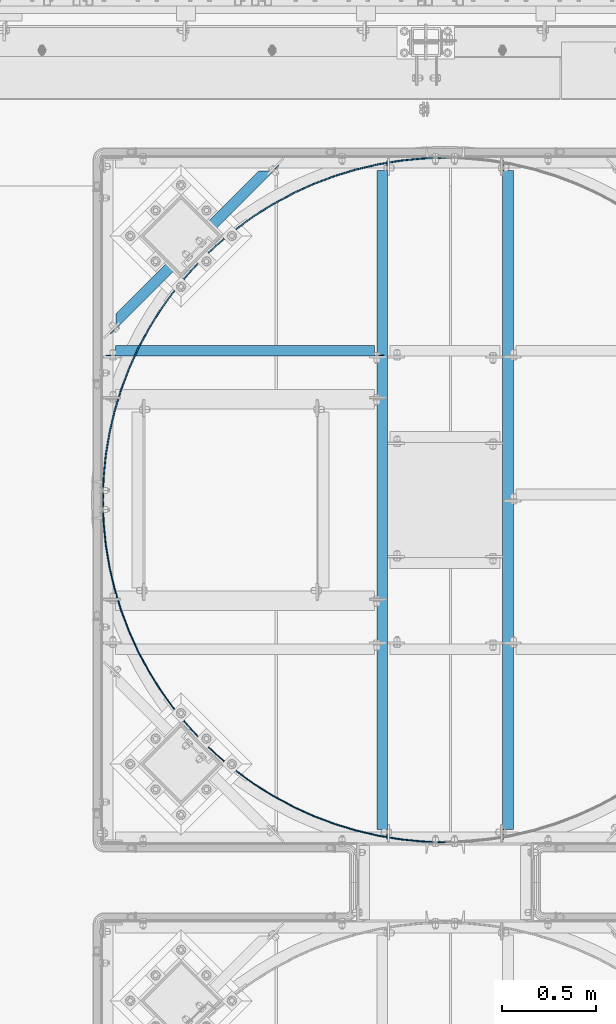
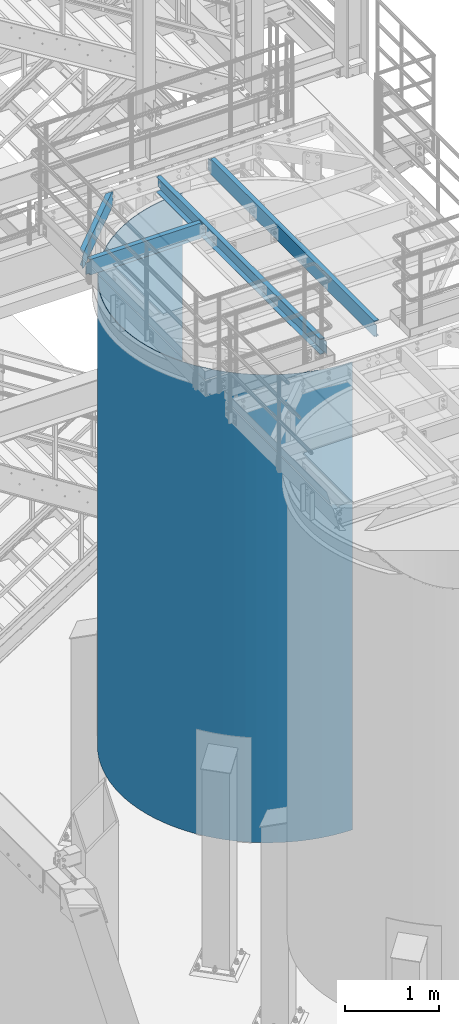
# One storey, part 939 of 1876: 5 beams, 5 elements without a shape of their own.
"""IFC2X3 building model written with IfcOpenShell, lengths in millimetres."""

from ifc_helpers import new_model, si_unit, frame, origin_with_axes, place, context, subcontext, project, spatial, faceted_brep, material, type_object, element, aggregate, save


model = new_model("IFC2X3")

# Units and contexts
model_context = context("Model", 3, precision=1e-05, world=origin_with_axes())
body_context = subcontext(model_context, "Body", "Model", "MODEL_VIEW")
ifc_project = project(units=[si_unit("LENGTHUNIT", "METRE", prefix="MILLI"), si_unit("AREAUNIT", "SQUARE_METRE"), si_unit("VOLUMEUNIT", "CUBIC_METRE"), si_unit("MASSUNIT", "GRAM", prefix="KILO"), si_unit("TIMEUNIT", "SECOND"), si_unit("PLANEANGLEUNIT", "RADIAN"), si_unit("SOLIDANGLEUNIT", "STERADIAN"), si_unit("THERMODYNAMICTEMPERATUREUNIT", "DEGREE_CELSIUS"), si_unit("LUMINOUSINTENSITYUNIT", "LUMEN")], contexts=[model_context])

# Site, building, storey
site_placement = place(None, origin_with_axes())
site = spatial("IfcSite", under=ifc_project, at=site_placement, CompositionType="ELEMENT")
building_placement = place(site_placement, origin_with_axes())
building = spatial("IfcBuilding", under=site, at=building_placement, Name="Undefined", CompositionType="ELEMENT")
storey_placement = place(building_placement, origin_with_axes())
storey = spatial("IfcBuildingStorey", under=building, at=storey_placement, Name="Undefined", CompositionType="ELEMENT", Elevation=0.0)

# Assembly, beam
assembly_1_placement = place(storey_placement, origin_with_axes())
assembly_1 = element("IfcElementAssembly", 1, at=assembly_1_placement, inside=storey, Name="BEAM", AssemblyPlace="NOTDEFINED", PredefinedType="RIGID_FRAME")
ifc_material = material(Name="STEEL/A36")
beam_type_1 = type_object("IfcBeamType", Name="C8X11.5", PredefinedType="NOTDEFINED")
beam_1_placement = place(assembly_1_placement, frame((3349.46494957744, -8680.05257802322, 7896.225), z_axis=(0.0, 0.0, -1.0), x_axis=(0.707106781186548, 0.707106781186547, 0.0)))
beam_1 = element("IfcBeam", 2, at=beam_1_placement, type_object=beam_type_1, material=ifc_material, Name="BEAM", ObjectType="C8X11.5", context=body_context, shape_type="Brep", body=[
    faceted_brep([(154.529650862243, -28.5750000000025, 101.6), (154.529650862243, -28.5750000000025, 96.8355949999996), (1223.65903142988, -28.5750000000044, 96.8355949999996), (1223.65903142988, -28.5750000000044, 101.6), (1280.80903142989, 28.5750000000044, 101.6), (1271.29165562398, 19.0576241940962, 88.899999809264), (1280.80903142989, 28.5750000000044, 88.899999809264), (97.3796508622331, 28.5750000000062, 101.6), (97.3796508622331, 28.5750000000062, 88.899999809265), (106.897026668147, 19.0576241940926, 88.899999809265), (1298.76954340093, 28.5750000000062, -76.2000000000007), (1292.41954340093, 22.225000000004, -76.2000000000007), (1285.5463530323, 22.225000000004, -77.1667299225883), (1291.8963530323, 28.5750000000062, -77.1667299225883), (1279.71954359166, 22.225000000004, -79.9197438230667), (1286.06954359167, 28.5750000000044, -79.9197438230667), (1275.8261939962, 22.225000000004, -84.0399202912204), (1282.17619399621, 28.5750000000062, -84.0399202912204), (1274.60747157567, 22.225000000004, -88.3723149999996), (1271.29165562261, 19.0576241940853, -88.8999998092659), (1280.80903142853, 28.5750000000062, -88.8999998092659), (103.581210715046, 22.225000000004, -88.3723149999996), (106.897026668097, 19.0576241940926, -88.899999809265), (154.529650862193, -28.5750000000044, -96.8355949999996), (1223.65903142852, -28.5750000000044, -96.8355949999996), (154.529650862193, -28.5750000000044, -101.6), (1223.65903142852, -28.5750000000044, -101.6), (1280.80903142853, 28.5750000000062, -101.6), (97.3796508621845, 28.5750000000044, -101.6), (97.3796508621845, 28.5750000000044, -88.899999809265), (102.362488294509, 22.225000000004, -84.0399202912195), (96.0124882945074, 28.5750000000062, -84.0399202912195), (98.4691386990489, 22.2250000000058, -79.9197438230658), (92.1191386990495, 28.5750000000044, -79.9197438230658), (92.6423292584141, 22.225000000004, -77.1667299225874), (86.2923292584137, 28.5750000000044, -77.1667299225874), (85.7691388897797, 22.225000000004, -76.1999999999998), (79.4191388897784, 28.5750000000062, -76.1999999999998), (59.1474759898592, 22.225000000004, -76.1999999999998), (59.1474759898588, 28.5750000000062, -76.1999999999998), (59.1474759898592, 22.225000000004, 76.1999999999998), (59.1474759898588, 28.5750000000062, 76.1999999999998), (85.7691388898302, 22.225000000004, 76.1999999999998), (79.4191388898289, 28.5750000000062, 76.1999999999998), (92.6423292584636, 22.225000000004, 77.1667299225874), (86.2923292584624, 28.5750000000062, 77.1667299225874), (98.4691386990994, 22.225000000004, 79.9197438230658), (92.119138699099, 28.5750000000062, 79.9197438230658), (102.362488294559, 22.225000000004, 84.0399202912195), (96.0124882945579, 28.5750000000062, 84.0399202912195), (103.581210715098, 22.225000000004, 88.3723149999996), (1274.60747157703, 22.225000000004, 88.3723149999996), (1275.82619399757, 22.225000000004, 84.0399202912186), (1282.17619399757, 28.5750000000062, 84.0399202912186), (1279.71954359303, 22.225000000004, 79.9197438230649), (1286.06954359303, 28.5750000000062, 79.9197438230649), (1285.54635303366, 22.225000000004, 77.1667299225865), (1291.89635303366, 28.5750000000044, 77.1667299225865), (1292.4195434023, 22.225000000004, 76.1999999999989), (1298.7695434023, 28.5750000000062, 76.1999999999989), (1319.04120629678, 22.225000000004, 76.1999999999989), (1319.04120629678, 28.5750000000062, 76.1999999999989), (1319.04120629678, 28.5750000000062, -76.2000000000007), (1319.04120629678, 22.225000000004, -76.2000000000007)], [[[0, 1, 2, 3]], [[4, 3, 2, 5, 6]], [[7, 0, 3, 4]], [[0, 7, 8, 9, 1]], [[10, 11, 12, 13]], [[13, 12, 14, 15]], [[15, 14, 16, 17]], [[17, 16, 18, 19, 20]], [[21, 22, 23, 24, 19, 18]], [[23, 25, 26, 24]], [[20, 19, 24, 26, 27]], [[25, 28, 27, 26]], [[23, 22, 29, 28, 25]], [[21, 30, 31, 29, 22]], [[32, 33, 31, 30]], [[34, 35, 33, 32]], [[36, 37, 35, 34]], [[37, 36, 38, 39]], [[39, 38, 40, 41]], [[42, 43, 41, 40]], [[44, 45, 43, 42]], [[46, 47, 45, 44]], [[48, 49, 47, 46]], [[9, 8, 49, 48, 50]], [[2, 1, 9, 50, 51, 5]], [[6, 5, 51, 52, 53]], [[53, 52, 54, 55]], [[55, 54, 56, 57]], [[57, 56, 58, 59]], [[59, 58, 60, 61]], [[10, 13, 15, 17, 20, 27, 28, 29, 31, 33, 35, 37, 39, 41, 43, 45, 47, 49, 8, 7, 4, 6, 53, 55, 57, 59, 61, 62]], [[11, 10, 62, 63]], [[58, 56, 54, 52, 51, 50, 48, 46, 44, 42, 40, 38, 36, 34, 32, 30, 21, 18, 16, 14, 12, 11, 63, 60]], [[62, 61, 60, 63]]]),
])
aggregate(assembly_1, [beam_1])

assembly_2_placement = place(storey_placement, origin_with_axes())
assembly_2 = element("IfcElementAssembly", 3, at=assembly_2_placement, inside=storey, Name="BEAM", AssemblyPlace="NOTDEFINED", PredefinedType="RIGID_FRAME")
beam_2_placement = place(assembly_2_placement, frame((3365.50333884985, -8747.08935546873, 7896.225), z_axis=(0.0, 0.0, -1.0), x_axis=(1.0, 0.0, 0.0)))
beam_2 = element("IfcBeam", 4, at=beam_2_placement, type_object=beam_type_1, material=ifc_material, Name="BEAM", ObjectType="C8X11.5", context=body_context, shape_type="Brep", body=[
    faceted_brep([(1441.45, -28.5750000000007, -96.8355949999996), (1441.45, -28.5750000000007, -101.6), (1441.45, 28.5750000000007, -101.6), (1441.45, 28.5750000000007, -88.899999809264), (1441.45, 19.0576241940926, -88.899999809264), (1441.55496303464, 22.2250000000004, -88.3723149999996), (1442.41672992259, 28.5750000000007, -84.0399202912186), (1442.41672992259, 22.2250000000004, -84.0399202912186), (1445.16974382306, 28.5750000000007, -79.9197438230649), (1445.16974382306, 22.2250000000004, -79.9197438230649), (1449.28992029122, 28.5750000000007, -77.1667299225865), (1449.28992029122, 22.2250000000004, -77.1667299225865), (1454.14999980926, 28.5750000000007, -76.1999999999989), (1454.14999980926, 22.2250000000004, -76.1999999999989), (1492.25, 22.2250000000004, -76.1999999999989), (1492.25, 28.5750000000007, -76.1999999999989), (69.8500000000013, 28.5750000000007, 101.6), (69.8500000000013, -28.5750000000007, 101.6), (1441.45, -28.5750000000007, 101.6), (1441.45, 28.5750000000007, 101.6), (69.8500000000013, 19.0576241940817, -88.8999998092659), (69.8500000000013, 28.5750000000007, -88.8999998092659), (69.8500000000013, 28.5750000000007, -101.6), (69.8500000000013, -28.5750000000007, -101.6), (69.8500000000013, -28.5750000000007, -96.8355949999996), (69.7450369653598, 22.2250000000004, -88.3723149999996), (68.8832700774137, 22.2250000000004, -84.0399202912204), (68.8832700774137, 28.5750000000007, -84.0399202912204), (66.1302561769353, 22.2250000000004, -79.9197438230667), (66.1302561769353, 28.5750000000007, -79.9197438230667), (62.0100797087816, 22.2250000000004, -77.1667299225883), (62.0100797087816, 28.5750000000007, -77.1667299225883), (57.1500001907361, 22.2250000000004, -76.2000000000007), (57.1500001907361, 28.5750000000007, -76.2000000000007), (19.0499999999993, 22.2250000000004, -76.2000000000007), (19.0499999999993, 28.5750000000007, -76.2000000000007), (19.0499999999993, 22.2250000000004, 76.1999999999989), (19.0499999999993, 28.5750000000007, 76.1999999999989), (57.1500001907361, 22.2250000000004, 76.1999999999989), (57.1500001907361, 28.5750000000007, 76.1999999999989), (62.0100797087816, 22.2250000000004, 77.1667299225865), (62.0100797087816, 28.5750000000007, 77.1667299225865), (66.1302561769353, 22.2250000000004, 79.9197438230649), (66.1302561769353, 28.5750000000007, 79.9197438230649), (68.8832700774137, 22.2250000000004, 84.0399202912186), (68.8832700774137, 28.5750000000007, 84.0399202912186), (69.8500000000013, 19.0576241940926, 88.899999809264), (69.8500000000013, 28.5750000000007, 88.899999809264), (69.7450369653607, 22.2250000000004, 88.3723149999996), (69.8500000000013, -28.5750000000007, 96.8355949999996), (1441.45, -28.5750000000007, 96.8355949999996), (1441.45, 19.0576241940817, 88.8999998092659), (1441.45, 28.5750000000007, 88.8999998092659), (1441.55496303464, 22.2250000000004, 88.3723149999996), (1442.41672992259, 22.2250000000004, 84.0399202912204), (1442.41672992259, 28.5750000000007, 84.0399202912204), (1445.16974382306, 22.2250000000004, 79.9197438230667), (1445.16974382306, 28.5750000000007, 79.9197438230667), (1449.28992029122, 22.2250000000004, 77.1667299225883), (1449.28992029122, 28.5750000000007, 77.1667299225883), (1454.14999980926, 22.2250000000004, 76.2000000000007), (1454.14999980926, 28.5750000000007, 76.2000000000007), (1492.25, 22.2250000000004, 76.2000000000007), (1492.25, 28.5750000000007, 76.2000000000007)], [[[0, 1, 2, 3, 4]], [[5, 4, 3, 6, 7]], [[7, 6, 8, 9]], [[9, 8, 10, 11]], [[11, 10, 12, 13]], [[14, 13, 12, 15]], [[16, 17, 18, 19]], [[20, 21, 22, 23, 24]], [[25, 26, 27, 21, 20]], [[28, 29, 27, 26]], [[30, 31, 29, 28]], [[32, 33, 31, 30]], [[34, 35, 33, 32]], [[36, 37, 35, 34]], [[38, 39, 37, 36]], [[40, 41, 39, 38]], [[42, 43, 41, 40]], [[44, 45, 43, 42]], [[46, 47, 45, 44, 48]], [[17, 16, 47, 46, 49]], [[17, 49, 50, 18]], [[18, 50, 51, 52, 19]], [[49, 46, 48, 53, 51, 50]], [[54, 55, 52, 51, 53]], [[56, 57, 55, 54]], [[58, 59, 57, 56]], [[60, 61, 59, 58]], [[62, 63, 61, 60]], [[63, 62, 14, 15]], [[10, 8, 6, 3, 2, 22, 21, 27, 29, 31, 33, 35, 37, 39, 41, 43, 45, 47, 16, 19, 52, 55, 57, 59, 61, 63, 15, 12]], [[23, 22, 2, 1]], [[24, 23, 1, 0]], [[25, 20, 24, 0, 4, 5]], [[62, 60, 58, 56, 54, 53, 48, 44, 42, 40, 38, 36, 34, 32, 30, 28, 26, 25, 5, 7, 9, 11, 13, 14]]]),
])
aggregate(assembly_2, [beam_2])

assembly_3_placement = place(storey_placement, origin_with_axes())
assembly_3 = element("IfcElementAssembly", 5, at=assembly_3_placement, inside=storey, Name="BEAM", AssemblyPlace="NOTDEFINED", PredefinedType="RIGID_FRAME")
beam_3_placement = place(assembly_3_placement, frame((5514.97833884985, -11353.7643554687, 7896.225), z_axis=(0.0, 0.0, 1.0), x_axis=(0.0, 1.0, 0.0)))
beam_3 = element("IfcBeam", 6, at=beam_3_placement, type_object=beam_type_1, material=ifc_material, Name="BEAM", ObjectType="C8X11.5", context=body_context, shape_type="Brep", body=[
    faceted_brep([(3562.3499511731, -28.5749999999998, -96.8355949999996), (3562.3499511731, -28.5749999999998, -101.6), (3562.3499511731, 28.5749999999998, -101.6), (3562.3499511731, 28.5749999999998, -88.899999809264), (3562.3499511731, 19.0576241940935, -88.899999809264), (3562.45491420774, 22.2250000000004, -88.3723149999996), (3563.31668109569, 28.5749999999998, -84.0399202912186), (3563.31668109569, 22.2250000000004, -84.0399202912186), (3566.06969499617, 28.5749999999998, -79.9197438230649), (3566.06969499617, 22.2250000000004, -79.9197438230649), (3570.18987146432, 28.5749999999998, -77.1667299225865), (3570.18987146432, 22.2250000000004, -77.1667299225865), (3575.04995098237, 28.5749999999998, -76.1999999999989), (3575.04995098237, 22.2250000000004, -76.1999999999989), (3613.1499511731, 22.2250000000004, -76.1999999999989), (3613.1499511731, 28.5749999999998, -76.1999999999989), (69.8500000000013, 28.5750000000007, 101.6), (69.8500000000013, -28.5750000000007, 101.6), (3562.3499511731, -28.5749999999998, 101.6), (3562.3499511731, 28.5749999999998, 101.6), (69.8500000000013, 19.0576241940817, -88.8999998092659), (69.8500000000013, 28.5750000000007, -88.8999998092659), (69.8500000000013, 28.5750000000007, -101.6), (69.8500000000013, -28.5750000000007, -101.6), (69.8500000000013, -28.5750000000007, -96.8355949999996), (69.7450369653598, 22.2250000000004, -88.3723149999996), (68.8832700774137, 22.2250000000004, -84.0399202912204), (68.8832700774137, 28.5750000000007, -84.0399202912204), (66.1302561769353, 22.2250000000004, -79.9197438230667), (66.1302561769353, 28.5750000000007, -79.9197438230667), (62.0100797087816, 22.2250000000004, -77.1667299225883), (62.0100797087816, 28.5750000000007, -77.1667299225883), (57.1500001907361, 22.2250000000004, -76.2000000000007), (57.1500001907361, 28.5750000000007, -76.2000000000007), (19.0499999999993, 22.2250000000004, -76.2000000000007), (19.0499999999993, 28.5750000000007, -76.2000000000007), (19.0499999999993, 22.2250000000004, 76.1999999999989), (19.0499999999993, 28.5750000000007, 76.1999999999989), (57.1500001907361, 22.2250000000004, 76.1999999999989), (57.1500001907361, 28.5750000000007, 76.1999999999989), (62.0100797087816, 22.2250000000004, 77.1667299225865), (62.0100797087816, 28.5750000000007, 77.1667299225865), (66.1302561769353, 22.2250000000004, 79.9197438230649), (66.1302561769353, 28.5750000000007, 79.9197438230649), (68.8832700774137, 22.2250000000004, 84.0399202912186), (68.8832700774137, 28.5750000000007, 84.0399202912186), (69.8500000000013, 19.0576241940926, 88.899999809264), (69.8500000000013, 28.5750000000007, 88.899999809264), (69.7450369653607, 22.2250000000004, 88.3723149999996), (69.8500000000013, -28.5750000000007, 96.8355949999996), (3562.3499511731, -28.5749999999998, 96.8355949999996), (3562.3499511731, 19.0576241940826, 88.8999998092659), (3562.3499511731, 28.5749999999998, 88.8999998092659), (3562.45491420775, 22.2250000000004, 88.3723149999996), (3563.31668109569, 22.2250000000004, 84.0399202912204), (3563.31668109569, 28.5749999999998, 84.0399202912204), (3566.06969499617, 22.2250000000004, 79.9197438230667), (3566.06969499617, 28.5749999999998, 79.9197438230667), (3570.18987146432, 22.2250000000004, 77.1667299225883), (3570.18987146432, 28.5749999999998, 77.1667299225883), (3575.04995098237, 22.2250000000004, 76.2000000000007), (3575.04995098237, 28.5749999999998, 76.2000000000007), (3613.1499511731, 22.2250000000004, 76.2000000000007), (3613.1499511731, 28.5749999999998, 76.2000000000007)], [[[0, 1, 2, 3, 4]], [[5, 4, 3, 6, 7]], [[7, 6, 8, 9]], [[9, 8, 10, 11]], [[11, 10, 12, 13]], [[14, 13, 12, 15]], [[16, 17, 18, 19]], [[20, 21, 22, 23, 24]], [[25, 26, 27, 21, 20]], [[28, 29, 27, 26]], [[30, 31, 29, 28]], [[32, 33, 31, 30]], [[34, 35, 33, 32]], [[36, 37, 35, 34]], [[38, 39, 37, 36]], [[40, 41, 39, 38]], [[42, 43, 41, 40]], [[44, 45, 43, 42]], [[46, 47, 45, 44, 48]], [[17, 16, 47, 46, 49]], [[17, 49, 50, 18]], [[18, 50, 51, 52, 19]], [[49, 46, 48, 53, 51, 50]], [[54, 55, 52, 51, 53]], [[56, 57, 55, 54]], [[58, 59, 57, 56]], [[60, 61, 59, 58]], [[62, 63, 61, 60]], [[63, 62, 14, 15]], [[10, 8, 6, 3, 2, 22, 21, 27, 29, 31, 33, 35, 37, 39, 41, 43, 45, 47, 16, 19, 52, 55, 57, 59, 61, 63, 15, 12]], [[23, 22, 2, 1]], [[24, 23, 1, 0]], [[25, 20, 24, 0, 4, 5]], [[62, 60, 58, 56, 54, 53, 48, 44, 42, 40, 38, 36, 34, 32, 30, 28, 26, 25, 5, 7, 9, 11, 13, 14]]]),
])
aggregate(assembly_3, [beam_3])

assembly_4_placement = place(storey_placement, origin_with_axes())
assembly_4 = element("IfcElementAssembly", 7, at=assembly_4_placement, inside=storey, Name="BEAM", AssemblyPlace="NOTDEFINED", PredefinedType="RIGID_FRAME")
beam_4_placement = place(assembly_4_placement, frame((4848.22833884985, -11353.7643554687, 7896.225), z_axis=(0.0, 0.0, -1.0), x_axis=(0.0, 1.0, 0.0)))
beam_4 = element("IfcBeam", 8, at=beam_4_placement, type_object=beam_type_1, material=ifc_material, Name="BEAM", ObjectType="C8X11.5", context=body_context, shape_type="Brep", body=[
    faceted_brep([(3562.3499511731, -28.5749999999998, -96.8355949999996), (3562.3499511731, -28.5749999999998, -101.6), (3562.3499511731, 28.5749999999998, -101.6), (3562.3499511731, 28.5749999999998, -88.899999809264), (3562.3499511731, 19.0576241940935, -88.899999809264), (3562.45491420774, 22.2250000000004, -88.3723149999996), (3563.31668109569, 28.5749999999998, -84.0399202912186), (3563.31668109569, 22.2250000000004, -84.0399202912186), (3566.06969499617, 28.5749999999998, -79.9197438230649), (3566.06969499617, 22.2250000000004, -79.9197438230649), (3570.18987146432, 28.5749999999998, -77.1667299225865), (3570.18987146432, 22.2250000000004, -77.1667299225865), (3575.04995098237, 28.5749999999998, -76.1999999999989), (3575.04995098237, 22.2250000000004, -76.1999999999989), (3613.1499511731, 22.2250000000004, -76.1999999999989), (3613.1499511731, 28.5749999999998, -76.1999999999989), (69.8500000000013, 28.5750000000007, 101.6), (69.8500000000013, -28.5750000000007, 101.6), (3562.3499511731, -28.5749999999998, 101.6), (3562.3499511731, 28.5749999999998, 101.6), (69.8500000000013, 19.0576241940817, -88.8999998092659), (69.8500000000013, 28.5750000000007, -88.8999998092659), (69.8500000000013, 28.5750000000007, -101.6), (69.8500000000013, -28.5750000000007, -101.6), (69.8500000000013, -28.5750000000007, -96.8355949999996), (69.7450369653598, 22.2250000000004, -88.3723149999996), (68.8832700774137, 22.2250000000004, -84.0399202912204), (68.8832700774137, 28.5750000000007, -84.0399202912204), (66.1302561769353, 22.2250000000004, -79.9197438230667), (66.1302561769353, 28.5750000000007, -79.9197438230667), (62.0100797087816, 22.2250000000004, -77.1667299225883), (62.0100797087816, 28.5750000000007, -77.1667299225883), (57.1500001907361, 22.2250000000004, -76.2000000000007), (57.1500001907361, 28.5750000000007, -76.2000000000007), (19.0499999999993, 22.2250000000004, -76.2000000000007), (19.0499999999993, 28.5750000000007, -76.2000000000007), (19.0499999999993, 22.2250000000004, 76.1999999999989), (19.0499999999993, 28.5750000000007, 76.1999999999989), (57.1500001907361, 22.2250000000004, 76.1999999999989), (57.1500001907361, 28.5750000000007, 76.1999999999989), (62.0100797087816, 22.2250000000004, 77.1667299225865), (62.0100797087816, 28.5750000000007, 77.1667299225865), (66.1302561769353, 22.2250000000004, 79.9197438230649), (66.1302561769353, 28.5750000000007, 79.9197438230649), (68.8832700774137, 22.2250000000004, 84.0399202912186), (68.8832700774137, 28.5750000000007, 84.0399202912186), (69.8500000000013, 19.0576241940926, 88.899999809264), (69.8500000000013, 28.5750000000007, 88.899999809264), (69.7450369653607, 22.2250000000004, 88.3723149999996), (69.8500000000013, -28.5750000000007, 96.8355949999996), (3562.3499511731, -28.5749999999998, 96.8355949999996), (3562.3499511731, 19.0576241940826, 88.8999998092659), (3562.3499511731, 28.5749999999998, 88.8999998092659), (3562.45491420775, 22.2250000000004, 88.3723149999996), (3563.31668109569, 22.2250000000004, 84.0399202912204), (3563.31668109569, 28.5749999999998, 84.0399202912204), (3566.06969499617, 22.2250000000004, 79.9197438230667), (3566.06969499617, 28.5749999999998, 79.9197438230667), (3570.18987146432, 22.2250000000004, 77.1667299225883), (3570.18987146432, 28.5749999999998, 77.1667299225883), (3575.04995098237, 22.2250000000004, 76.2000000000007), (3575.04995098237, 28.5749999999998, 76.2000000000007), (3613.1499511731, 22.2250000000004, 76.2000000000007), (3613.1499511731, 28.5749999999998, 76.2000000000007)], [[[0, 1, 2, 3, 4]], [[5, 4, 3, 6, 7]], [[7, 6, 8, 9]], [[9, 8, 10, 11]], [[11, 10, 12, 13]], [[14, 13, 12, 15]], [[16, 17, 18, 19]], [[20, 21, 22, 23, 24]], [[25, 26, 27, 21, 20]], [[28, 29, 27, 26]], [[30, 31, 29, 28]], [[32, 33, 31, 30]], [[34, 35, 33, 32]], [[36, 37, 35, 34]], [[38, 39, 37, 36]], [[40, 41, 39, 38]], [[42, 43, 41, 40]], [[44, 45, 43, 42]], [[46, 47, 45, 44, 48]], [[17, 16, 47, 46, 49]], [[17, 49, 50, 18]], [[18, 50, 51, 52, 19]], [[49, 46, 48, 53, 51, 50]], [[54, 55, 52, 51, 53]], [[56, 57, 55, 54]], [[58, 59, 57, 56]], [[60, 61, 59, 58]], [[62, 63, 61, 60]], [[63, 62, 14, 15]], [[10, 8, 6, 3, 2, 22, 21, 27, 29, 31, 33, 35, 37, 39, 41, 43, 45, 47, 16, 19, 52, 55, 57, 59, 61, 63, 15, 12]], [[23, 22, 2, 1]], [[24, 23, 1, 0]], [[25, 20, 24, 0, 4, 5]], [[62, 60, 58, 56, 54, 53, 48, 44, 42, 40, 38, 36, 34, 32, 30, 28, 26, 25, 5, 7, 9, 11, 13, 14]]]),
])
aggregate(assembly_4, [beam_4])

assembly_5_placement = place(storey_placement, origin_with_axes())
assembly_5 = element("IfcElementAssembly", 9, at=assembly_5_placement, inside=storey, Name="PLATE", AssemblyPlace="NOTDEFINED", PredefinedType="RIGID_FRAME")
beam_type_2 = type_object("IfcBeamType", PredefinedType="NOTDEFINED")
beam_5_placement = place(assembly_5_placement, frame((5183.84837846666, -11351.5192914385, 4572.0), z_axis=(0.0, 0.0, 1.0), x_axis=(-0.707106781186548, 0.707106781186547, 0.0)))
beam_5 = element("IfcBeam", 10, at=beam_5_placement, type_object=beam_type_2, material=ifc_material, Name="PLATE", context=body_context, shape_type="Brep", body=[
    faceted_brep([(4.49012806053543, -1.31512806053706, -3048.0), (4.49012806053543, -1.31512806053706, 3048.0), (0.0, 3.17500000000018, 3048.0), (0.0, 3.17500000000018, -3048.0), (86.7386893436651, 84.4146479575566, 3048.0), (86.7386893436651, 84.4146479575566, -3048.0), (90.9255352695491, 79.6404651800631, -3048.0), (90.9255352695491, 79.6404651800631, 3048.0), (182.470626763443, 154.769580173522, -3048.0), (182.470626763443, 154.769580173522, 3048.0), (178.604991689237, 159.807373884371, 3048.0), (178.604991689237, 159.807373884371, -3048.0), (278.733392406179, 223.750502515405, -3048.0), (278.733392406179, 223.750502515405, 3048.0), (275.205521426506, 229.030334553528, 3048.0), (275.205521426506, 229.030334553528, -3048.0), (379.301620256749, 286.287845306104, -3048.0), (379.301620256749, 286.287845306104, 3048.0), (376.126620256751, 291.787106620136, 3048.0), (376.126620256751, 291.787106620136, -3048.0), (483.744661723982, 342.113814042878, -3048.0), (483.744661723982, 342.113814042878, 3048.0), (480.936128541092, 347.808955951613, 3048.0), (480.936128541092, 347.808955951613, -3048.0), (591.615275669927, 390.989353357043, -3048.0), (591.615275669927, 390.989353357043, 3048.0), (589.185235874411, 396.855988388491, 3048.0), (589.185235874411, 396.855988388491, -3048.0), (702.451543565072, 432.705170685742, -3048.0), (702.451543565072, 432.705170685742, 3048.0), (700.410402960399, 438.718177008037, 3048.0), (700.410402960399, 438.718177008037, -3048.0), (815.778847494395, 467.082632494846, -3048.0), (815.778847494395, 467.082632494846, 3048.0), (814.135346557994, 473.216261491782, 3048.0), (814.135346557994, 473.216261491782, -3048.0), (931.111902544148, 493.974529215167, -3048.0), (931.111902544148, 493.974529215167, 3048.0), (929.873078999346, 500.202515745727, 3048.0), (929.873078999346, 500.202515745727, -3048.0), (1047.95683486635, 513.265705616425, -3048.0), (1047.95683486635, 513.265705616425, 3048.0), (1047.12799354576, 519.56138048615, 3048.0), (1047.12799354576, 519.56138048615, -3048.0), (1165.81329652245, 524.873553919638, -3048.0), (1165.81329652245, 524.873553919638, 3048.0), (1165.39798665184, 531.209958082205, 3048.0), (1165.39798665184, 531.209958082205, -3048.0), (1284.17660804998, 528.748367536302, -3048.0), (1284.17660804998, 528.748367536302, 3048.0), (1284.17660804998, 535.098367536303, 3048.0), (1284.17660804998, 535.098367536303, -3048.0), (1402.5399195775, 524.873553919638, -3048.0), (1402.5399195775, 524.873553919638, 3048.0), (1402.95522944811, 531.209958082204, 3048.0), (1402.95522944811, 531.209958082204, -3048.0), (1520.3963812336, 513.265705616425, -3048.0), (1520.3963812336, 513.265705616425, 3048.0), (1521.2252225542, 519.56138048615, 3048.0), (1521.2252225542, 519.56138048615, -3048.0), (1637.24131355581, 493.974529215165, -3048.0), (1637.24131355581, 493.974529215165, 3048.0), (1638.48013710061, 500.202515745727, 3048.0), (1638.48013710061, 500.202515745727, -3048.0), (1752.57436860556, 467.082632494848, -3048.0), (1752.57436860556, 467.082632494848, 3048.0), (1754.21786954196, 473.216261491783, 3048.0), (1754.21786954196, 473.216261491783, -3048.0), (1865.90167253488, 432.705170685741, -3048.0), (1865.90167253488, 432.705170685741, 3048.0), (1867.94281313955, 438.718177008038, 3048.0), (1867.94281313955, 438.718177008038, -3048.0), (1976.73794043002, 390.989353357042, -3048.0), (1976.73794043002, 390.989353357042, 3048.0), (1979.16798022554, 396.855988388491, 3048.0), (1979.16798022554, 396.855988388491, -3048.0), (2084.60855437597, 342.113814042878, -3048.0), (2084.60855437597, 342.113814042878, 3048.0), (2087.41708755886, 347.808955951613, 3048.0), (2087.41708755886, 347.808955951613, -3048.0), (2189.0515958432, 286.287845306103, -3048.0), (2189.0515958432, 286.287845306103, 3048.0), (2192.2265958432, 291.787106620135, 3048.0), (2192.2265958432, 291.787106620135, -3048.0), (2289.61982369377, 223.750502515403, -3048.0), (2289.61982369377, 223.750502515403, 3048.0), (2293.14769467345, 229.030334553528, 3048.0), (2293.14769467345, 229.030334553528, -3048.0), (2385.88258933651, 154.76958017352, -3048.0), (2385.88258933651, 154.76958017352, 3048.0), (2389.74822441072, 159.807373884371, 3048.0), (2389.74822441072, 159.807373884371, -3048.0), (2477.4276808304, 79.6404651800613, -3048.0), (2477.4276808304, 79.6404651800613, 3048.0), (2481.61452675629, 84.4146479575547, 3048.0), (2481.61452675629, 84.4146479575547, -3048.0), (2563.86308803942, -1.31512806053706, -3048.0), (2563.86308803942, -1.31512806053706, 3048.0), (2568.35321609995, 3.17499999999927, 3048.0), (2568.35321609995, 3.17500000000018, -3048.0), (2649.59286405754, -83.5636893436485, 3048.0), (2649.59286405754, -83.5636893436485, -3048.0), (2724.98558998438, -175.429991689211, -3048.0), (2794.20855065357, -272.03052142647, -3048.0), (2856.9653227202, -372.951620256707, -3048.0), (2912.9871720517, -477.761128541047, -3048.0), (2962.03420448861, -586.010235874364, -3048.0), (3003.89639310817, -697.235402960353, -3048.0), (3038.39447759194, -810.960346557953, -3048.0), (3065.3807318459, -926.69807899931, -3048.0), (3084.73959658634, -1043.95299354573, -3048.0), (3096.3881741824, -1162.22298665182, -3048.0), (3100.27658363651, -1281.00160804996, -3048.0), (3096.38817418242, -1399.78022944811, -3048.0), (3084.73959658637, -1518.0502225542, -3048.0), (3065.38073184595, -1635.30513710062, -3048.0), (3038.394477592, -1751.04286954198, -3048.0), (3003.89639310825, -1864.76781313959, -3048.0), (2962.0342044887, -1975.99298022558, -3048.0), (2912.98717205181, -2084.2420875589, -3048.0), (2856.96532272033, -2189.05159584325, -3048.0), (2794.20855065371, -2289.9726946735, -3048.0), (2724.98558998454, -2386.57322441077, -3048.0), (2649.5928640577, -2478.43952675634, -3048.0), (2568.35321610013, -2565.1782161, -3048.0), (2563.86308803959, -2560.68808803946, -3048.0), (2644.81868128021, -2474.25268083045, -3048.0), (2719.94779627369, -2382.70758933656, -3048.0), (2788.92871861559, -2286.44482369382, -3048.0), (2851.46606140629, -2185.87659584325, -3048.0), (2907.29203014308, -2081.43355437601, -3048.0), (2956.16756945725, -1973.56294043006, -3048.0), (2997.88338678596, -1862.72667253491, -3048.0), (3032.26084859507, -1749.39936860558, -3048.0), (3059.15274531539, -1634.06631355582, -3048.0), (3078.44392171664, -1517.2213812336, -3048.0), (3090.05177001985, -1399.3649195775, -3048.0), (3093.92658363651, -1281.00160804996, -3048.0), (3090.05177001984, -1162.63829652243, -3048.0), (3078.44392171661, -1044.78183486633, -3048.0), (3059.15274531534, -927.936902544113, -3048.0), (3032.260848595, -812.603847494355, -3048.0), (2997.88338678588, -699.276543565029, -3048.0), (2956.16756945716, -588.440275669883, -3048.0), (2907.29203014297, -480.569661723938, -3048.0), (2851.46606140617, -376.126620256709, -3048.0), (2788.92871861544, -275.558392406144, -3048.0), (2719.94779627353, -179.295626763415, -3048.0), (2644.81868128004, -87.7505352695343, -3048.0), (2644.81868128004, -87.7505352695343, 3048.0), (2719.94779627353, -179.295626763415, 3048.0), (2788.92871861544, -275.558392406144, 3048.0), (2851.46606140617, -376.126620256709, 3048.0), (2907.29203014297, -480.569661723938, 3048.0), (2956.16756945716, -588.440275669883, 3048.0), (2997.88338678588, -699.276543565029, 3048.0), (3032.260848595, -812.603847494355, 3048.0), (3059.15274531534, -927.936902544113, 3048.0), (3078.44392171661, -1044.78183486633, 3048.0), (3090.05177001984, -1162.63829652243, 3048.0), (3093.92658363651, -1281.00160804996, 3048.0), (3090.05177001985, -1399.3649195775, 3048.0), (3078.44392171664, -1517.2213812336, 3048.0), (3059.15274531539, -1634.06631355582, 3048.0), (3032.26084859507, -1749.39936860558, 3048.0), (2997.88338678596, -1862.72667253491, 3048.0), (2956.16756945725, -1973.56294043006, 3048.0), (2907.29203014308, -2081.43355437601, 3048.0), (2851.46606140629, -2185.87659584325, 3048.0), (2788.92871861559, -2286.44482369382, 3048.0), (2719.94779627369, -2382.70758933656, 3048.0), (2644.81868128021, -2474.25268083045, 3048.0), (2563.86308803959, -2560.68808803946, 3048.0), (2568.35321610013, -2565.1782161, 3048.0), (2649.5928640577, -2478.43952675634, 3048.0), (2724.98558998454, -2386.57322441077, 3048.0), (2794.20855065371, -2289.9726946735, 3048.0), (2856.96532272033, -2189.05159584325, 3048.0), (2912.98717205181, -2084.2420875589, 3048.0), (2962.0342044887, -1975.99298022558, 3048.0), (3003.89639310825, -1864.76781313959, 3048.0), (3038.394477592, -1751.04286954198, 3048.0), (3065.38073184595, -1635.30513710062, 3048.0), (3084.73959658637, -1518.0502225542, 3048.0), (3096.38817418242, -1399.78022944811, 3048.0), (3100.27658363651, -1281.00160804996, 3048.0), (3096.3881741824, -1162.22298665182, 3048.0), (3084.73959658634, -1043.95299354573, 3048.0), (3065.3807318459, -926.69807899931, 3048.0), (3038.39447759194, -810.960346557953, 3048.0), (3003.89639310817, -697.235402960353, 3048.0), (2962.03420448861, -586.010235874364, 3048.0), (2912.9871720517, -477.761128541047, 3048.0), (2856.9653227202, -372.951620256708, 3048.0), (2794.20855065357, -272.030521426471, 3048.0), (2724.98558998438, -175.429991689211, 3048.0)], [[[0, 1, 2, 3]], [[3, 2, 4, 5]], [[1, 0, 6, 7]], [[6, 8, 9, 7]], [[4, 10, 11, 5]], [[8, 12, 13, 9]], [[10, 14, 15, 11]], [[12, 16, 17, 13]], [[14, 18, 19, 15]], [[16, 20, 21, 17]], [[18, 22, 23, 19]], [[20, 24, 25, 21]], [[22, 26, 27, 23]], [[24, 28, 29, 25]], [[26, 30, 31, 27]], [[28, 32, 33, 29]], [[30, 34, 35, 31]], [[32, 36, 37, 33]], [[34, 38, 39, 35]], [[36, 40, 41, 37]], [[38, 42, 43, 39]], [[40, 44, 45, 41]], [[42, 46, 47, 43]], [[44, 48, 49, 45]], [[46, 50, 51, 47]], [[48, 52, 53, 49]], [[50, 54, 55, 51]], [[52, 56, 57, 53]], [[54, 58, 59, 55]], [[56, 60, 61, 57]], [[58, 62, 63, 59]], [[60, 64, 65, 61]], [[62, 66, 67, 63]], [[64, 68, 69, 65]], [[66, 70, 71, 67]], [[68, 72, 73, 69]], [[70, 74, 75, 71]], [[72, 76, 77, 73]], [[74, 78, 79, 75]], [[76, 80, 81, 77]], [[78, 82, 83, 79]], [[80, 84, 85, 81]], [[82, 86, 87, 83]], [[84, 88, 89, 85]], [[86, 90, 91, 87]], [[88, 92, 93, 89]], [[90, 94, 95, 91]], [[92, 96, 97, 93]], [[94, 98, 99, 95]], [[99, 98, 100, 101]], [[102, 103, 104, 105, 106, 107, 108, 109, 110, 111, 112, 113, 114, 115, 116, 117, 118, 119, 120, 121, 122, 123, 124, 125, 126, 127, 128, 129, 130, 131, 132, 133, 134, 135, 136, 137, 138, 139, 140, 141, 142, 143, 144, 145, 146, 147, 148, 96, 92, 88, 84, 80, 76, 72, 68, 64, 60, 56, 52, 48, 44, 40, 36, 32, 28, 24, 20, 16, 12, 8, 6, 0, 3, 5, 11, 15, 19, 23, 27, 31, 35, 39, 43, 47, 51, 55, 59, 63, 67, 71, 75, 79, 83, 87, 91, 95, 99, 101]], [[97, 96, 148, 149]], [[150, 151, 152, 153, 154, 155, 156, 157, 158, 159, 160, 161, 162, 163, 164, 165, 166, 167, 168, 169, 170, 171, 172, 173, 174, 175, 176, 177, 178, 179, 180, 181, 182, 183, 184, 185, 186, 187, 188, 189, 190, 191, 192, 193, 194, 195, 100, 98, 94, 90, 86, 82, 78, 74, 70, 66, 62, 58, 54, 50, 46, 42, 38, 34, 30, 26, 22, 18, 14, 10, 4, 2, 1, 7, 9, 13, 17, 21, 25, 29, 33, 37, 41, 45, 49, 53, 57, 61, 65, 69, 73, 77, 81, 85, 89, 93, 97, 149]], [[148, 147, 150, 149]], [[100, 195, 102, 101]], [[147, 146, 151, 150]], [[195, 194, 103, 102]], [[146, 145, 152, 151]], [[194, 193, 104, 103]], [[145, 144, 153, 152]], [[193, 192, 105, 104]], [[144, 143, 154, 153]], [[192, 191, 106, 105]], [[143, 142, 155, 154]], [[191, 190, 107, 106]], [[142, 141, 156, 155]], [[190, 189, 108, 107]], [[141, 140, 157, 156]], [[189, 188, 109, 108]], [[140, 139, 158, 157]], [[188, 187, 110, 109]], [[139, 138, 159, 158]], [[187, 186, 111, 110]], [[138, 137, 160, 159]], [[186, 185, 112, 111]], [[137, 136, 161, 160]], [[185, 184, 113, 112]], [[136, 135, 162, 161]], [[184, 183, 114, 113]], [[135, 134, 163, 162]], [[183, 182, 115, 114]], [[134, 133, 164, 163]], [[182, 181, 116, 115]], [[133, 132, 165, 164]], [[181, 180, 117, 116]], [[132, 131, 166, 165]], [[180, 179, 118, 117]], [[131, 130, 167, 166]], [[179, 178, 119, 118]], [[130, 129, 168, 167]], [[178, 177, 120, 119]], [[129, 128, 169, 168]], [[177, 176, 121, 120]], [[128, 127, 170, 169]], [[176, 175, 122, 121]], [[127, 126, 171, 170]], [[175, 174, 123, 122]], [[172, 125, 124, 173]], [[126, 125, 172, 171]], [[174, 173, 124, 123]]]),
])
aggregate(assembly_5, [beam_5])

save(model, "model.ifc")
